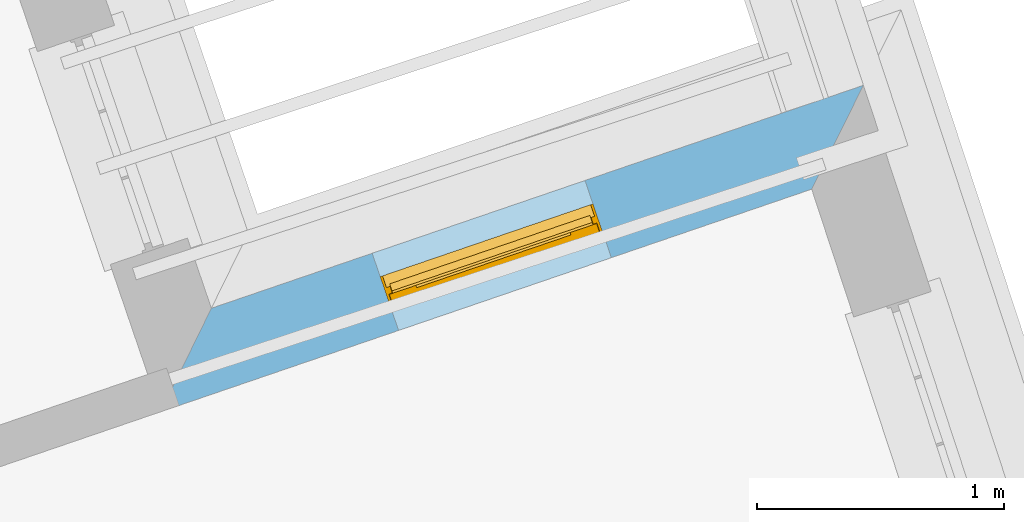
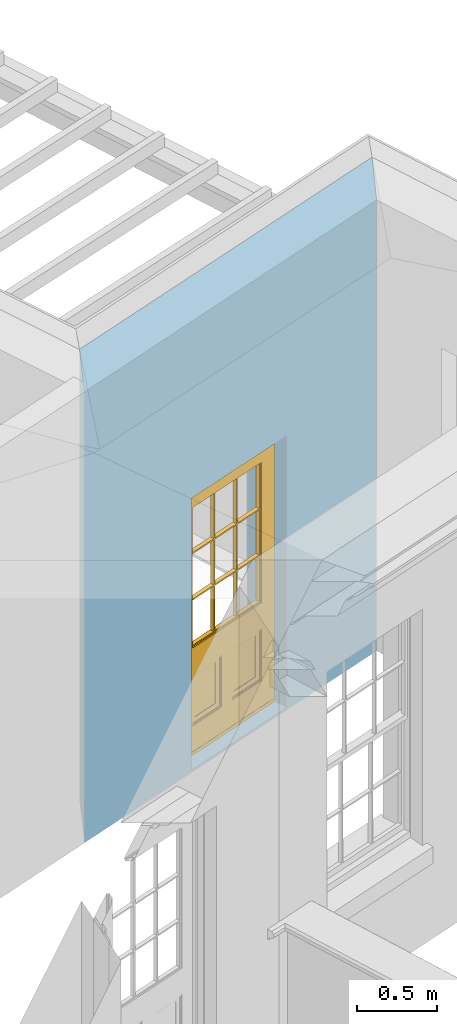
# One storey, part 6 of 10: 1 door, 1 opening, plus 1 element that does not belong to this part.
"""IFC2X3 building model written with IfcOpenShell, lengths in metres."""

from ifc_helpers import new_model, si_unit, frame, origin, place, context, subcontext, project, spatial, polyline, outline, extrude, faceted_brep, material, layer, layer_set, layer_usage, element, fill, save


model = new_model("IFC2X3")

# Units and contexts
model_context = context("Model", 3, world=origin())
body_context = subcontext(model_context, "Body", "Model", "MODEL_VIEW")
ifc_project = project(units=[si_unit("PLANEANGLEUNIT", "RADIAN"), si_unit("MASSUNIT", "GRAM", prefix="KILO"), si_unit("FORCEUNIT", "NEWTON", prefix="KILO"), si_unit("LENGTHUNIT", "METRE")], contexts=[model_context])

# Site, building, storey
site_placement = place(None, origin())
site = spatial("IfcSite", under=ifc_project, at=site_placement, CompositionType="ELEMENT")
building_placement = place(None, origin())
building = spatial("IfcBuilding", under=site, at=building_placement, Name="Building plot-2", CompositionType="ELEMENT")
storey_placement = place(None, frame((0.0, 0.0, 8.2)))
storey = spatial("IfcBuildingStorey", under=building, at=storey_placement, Name="Floor 2", CompositionType="ELEMENT", Elevation=8.2)

# Wall, opening, door
ifc_material = material(Name="Masonry")
ifc_layer = layer(ifc_material, 0.33, ventilated=False)
ifc_layer_set = layer_set([ifc_layer], Name="My Wall")
ifc_layer_usage = layer_usage(ifc_layer_set, "AXIS2", "NEGATIVE", 0.08)
wall_placement = place(storey_placement, origin())
wall = element("IfcWallStandardCase", 1, at=wall_placement, inside=storey, material=ifc_layer_usage, Name="exterior", context=body_context, shape_type="SweptSolid", body=[
    extrude(outline(polyline([(36.0640612033558, 35.8130809593384), (36.2732006834394, 36.2333480972997), (33.6348927431004, 35.33124781613), (33.4294074866547, 34.9122301442074), (36.0640612033558, 35.8130809593384)])), origin(), (0.0, 0.0, 1.0), 3.45),
])
opening_placement = place(storey_placement, frame((0.0, 0.0, 0.0199999999999996)))
opening = element("IfcOpeningElement", 2, at=opening_placement, cuts=wall, Name="Opening", ObjectType="Opening", context=body_context, shape_type="SweptSolid", body=[
    extrude(outline(polyline([(35.146636932067, 35.8481491365074), (34.2855798641652, 35.5537332303196), (34.3923460719036, 35.2414817661354), (35.2534031398054, 35.5358976723233), (35.146636932067, 35.8481491365074)])), origin(), (0.0, 0.0, 1.0), 2.08),
])
door_placement = place(storey_placement, frame((35.2275204227779, 35.611594996974, 0.0199999999999996), z_axis=(0.0, 0.0, 1.0), x_axis=(-0.861057067901783, -0.294415906187808, 0.0)))
door = element("IfcDoor", 3, at=door_placement, inside=storey, Name="circulation outside door", OverallHeight=2.08, OverallWidth=0.91, context=body_context, shape_type="Brep", held_by="IfcProductRepresentation", body=[
    faceted_brep([(0.545, -0.055, 0.265), (0.745, -0.055, 0.265), (0.745, -0.05, 0.265), (0.545, -0.05, 0.265), (0.745, -0.05, 0.58), (0.545, -0.05, 0.58), (0.545, -0.055, 0.58), (0.515, -0.06, 0.235), (0.775, -0.06, 0.235), (0.745, -0.055, 0.58), (0.515, -0.06, 0.61), (0.515, -0.065, 0.235), (0.775, -0.065, 0.235), (0.775, -0.06, 0.61), (0.515, -0.065, 0.61), (0.785, -0.065, 0.225), (0.505, -0.065, 0.225), (0.775, -0.065, 0.61), (0.505, -0.065, 0.62), (0.785, -0.065, 0.62), (0.505, -0.07, 0.225), (0.785, -0.07, 0.225), (0.505, -0.07, 0.62), (0.785, -0.07, 0.62), (0.883, -0.07, 0.075), (0.898, -0.07, 0.075), (0.405, -0.07, 0.62), (0.405, -0.07, 0.225), (0.027, -0.07, 0.075), (0.785, -0.07, 0.82), (0.125, -0.07, 0.82), (0.405, -0.065, 0.62), (0.405, -0.065, 0.225), (0.898, -0.07, 2.068), (0.027, -0.08, 0.075), (0.883, -0.08, 0.075), (0.125, -0.07, 0.225), (0.012, -0.07, 0.075), (0.785, -0.06, 0.82), (0.125, -0.06, 0.82), (0.125, -0.07, 0.62), (0.125, -0.065, 0.62), (0.395, -0.065, 0.61), (0.395, -0.065, 0.235), (0.125, -0.065, 0.225), (0.785, -0.07, 1.895), (0.027, -0.11, 0.045), (0.883, -0.11, 0.045), (0.558333, -0.06, 0.83), (0.351667, -0.06, 0.83), (0.125, -0.07, 1.895), (0.125, -0.06, 1.895), (0.785, -0.06, 1.895), (0.012, -0.07, 2.068), (0.135, -0.065, 0.61), (0.395, -0.06, 0.61), (0.395, -0.06, 0.235), (0.135, -0.065, 0.235), (0.027, -0.11, 0.027), (0.883, -0.11, 0.027), (0.568333, -0.06, 0.83), (0.558333, -0.03, 0.83), (0.351667, -0.03, 0.83), (0.341667, -0.06, 0.83), (0.135, -0.06, 1.185), (0.135, -0.06, 1.53), (0.775, -0.06, 1.53), (0.775, -0.06, 1.185), (0.135, -0.06, 0.61), (0.365, -0.055, 0.58), (0.365, -0.055, 0.265), (0.135, -0.06, 0.235), (0.568333, -0.06, 1.175), (0.558333, -0.06, 1.175), (0.775, -0.06, 0.83), (0.558333, -0.03, 1.175), (0.785, -0.03, 0.82), (0.125, -0.03, 0.82), (0.351667, -0.03, 1.175), (0.351667, -0.06, 1.175), (0.341667, -0.06, 1.175), (0.135, -0.06, 0.83), (0.135, -0.06, 1.175), (0.135, -0.03, 1.185), (0.135, -0.03, 1.53), (0.135, -0.06, 1.54), (0.351667, -0.06, 1.885), (0.558333, -0.06, 1.885), (0.775, -0.03, 1.53), (0.775, -0.03, 1.185), (0.775, -0.06, 1.175), (0.775, -0.06, 1.54), (0.165, -0.055, 0.58), (0.365, -0.05, 0.58), (0.365, -0.05, 0.265), (0.165, -0.055, 0.265), (0.568333, -0.03, 0.83), (0.568333, -0.03, 1.175), (0.568333, -0.06, 1.185), (0.558333, -0.06, 1.185), (0.775, -0.03, 0.83), (0.785, -0.02, 0.82), (0.125, -0.02, 0.82), (0.341667, -0.03, 0.83), (0.341667, -0.03, 1.175), (0.351667, -0.06, 1.185), (0.341667, -0.06, 1.185), (0.135, -0.03, 0.83), (0.341667, -0.03, 1.185), (0.125, -0.03, 1.895), (0.341667, -0.03, 1.53), (0.341667, -0.06, 1.53), (0.135, -0.06, 1.885), (0.341667, -0.06, 1.54), (0.341667, -0.06, 1.885), (0.558333, -0.03, 1.885), (0.351667, -0.03, 1.885), (0.568333, -0.06, 1.885), (0.785, -0.03, 1.895), (0.568333, -0.03, 1.185), (0.568333, -0.06, 1.53), (0.568333, -0.03, 1.53), (0.568333, -0.06, 1.54), (0.775, -0.06, 1.885), (0.165, -0.05, 0.58), (0.165, -0.05, 0.265), (0.775, -0.03, 1.175), (0.558333, -0.06, 1.53), (0.351667, -0.03, 1.185), (0.558333, -0.03, 1.185), (0.505, -0.02, 0.62), (0.405, -0.02, 0.62), (0.125, -0.02, 1.895), (0.785, -0.02, 1.895), (0.351667, -0.06, 1.53), (0.135, -0.03, 1.175), (0.135, -0.03, 1.54), (0.341667, -0.03, 1.54), (0.135, -0.03, 1.885), (0.351667, -0.06, 1.54), (0.558333, -0.03, 1.54), (0.558333, -0.06, 1.54), (0.351667, -0.03, 1.54), (0.775, -0.03, 1.54), (0.568333, -0.03, 1.54), (0.775, -0.03, 1.885), (0.558333, -0.03, 1.53), (0.405, -0.02, 0.225), (0.505, -0.02, 0.225), (0.125, -0.02, 0.62), (0.785, -0.02, 0.62), (0.012, -0.02, 2.068), (0.898, -0.02, 2.068), (0.351667, -0.03, 1.53), (0.341667, -0.03, 1.885), (0.568333, -0.03, 1.885), (0.405, -0.025, 0.225), (0.405, -0.025, 0.62), (0.505, -0.025, 0.62), (0.505, -0.025, 0.225), (0.898, -0.02, 0.027), (0.012, -0.02, 0.027), (0.125, -0.025, 0.62), (0.785, -0.025, 0.62), (0.395, -0.025, 0.235), (0.395, -0.025, 0.61), (0.125, -0.02, 0.225), (0.125, -0.025, 0.225), (0.515, -0.025, 0.61), (0.515, -0.025, 0.235), (0.785, -0.02, 0.225), (0.785, -0.025, 0.225), (0.135, -0.025, 0.61), (0.775, -0.025, 0.61), (0.135, -0.025, 0.235), (0.395, -0.03, 0.235), (0.395, -0.03, 0.61), (0.515, -0.03, 0.61), (0.515, -0.03, 0.235), (0.775, -0.025, 0.235), (0.135, -0.03, 0.61), (0.775, -0.03, 0.61), (0.135, -0.03, 0.235), (0.365, -0.035, 0.265), (0.365, -0.035, 0.58), (0.545, -0.035, 0.58), (0.545, -0.035, 0.265), (0.775, -0.03, 0.235), (0.165, -0.035, 0.58), (0.745, -0.035, 0.58), (0.165, -0.035, 0.265), (0.365, -0.04, 0.58), (0.365, -0.04, 0.265), (0.545, -0.04, 0.58), (0.545, -0.04, 0.265), (0.745, -0.035, 0.265), (0.165, -0.04, 0.58), (0.745, -0.04, 0.58), (0.165, -0.04, 0.265), (0.745, -0.04, 0.265), (0.885, -0.072, 0.025), (0.025, -0.072, 0.025), (0.025, -0.1, 0.025), (0.885, -0.1, 0.025), (0.9, -0.02, 0.025), (0.01, -0.02, 0.025), (0.9, -0.072, 0.025), (0.91, -0.02, 0.0), (0.0, -0.02, 0.0), (0.01, -0.072, 0.025), (0.9, -0.072, 2.07), (0.9, -0.02, 2.07), (0.885, -0.072, 2.055), (0.91, -0.02, 2.08), (0.01, -0.02, 2.07), (0.0, -0.02, 2.08), (0.01, -0.072, 2.07), (0.025, -0.072, 2.055), (0.0, -0.15, 2.08), (0.91, -0.15, 2.08), (0.01, -0.15, 2.07), (0.9, -0.15, 2.07), (0.01, -0.1, 2.07), (0.9, -0.1, 2.07), (0.0, -0.15, 0.0), (0.91, -0.15, 0.0), (0.01, -0.15, 0.025), (0.9, -0.15, 0.025), (0.01, -0.1, 0.025), (0.025, -0.1, 2.055), (0.9, -0.1, 0.025), (0.885, -0.1, 2.055), (0.898, -0.07, 0.027), (0.012, -0.07, 0.027), (0.883, -0.07, 0.027), (0.027, -0.07, 0.027)], [[[0, 1, 2, 3]], [[2, 4, 5, 3]], [[0, 3, 5, 6]], [[1, 0, 7, 8]], [[9, 4, 2, 1]], [[9, 6, 5, 4]], [[0, 6, 10, 7]], [[8, 7, 11, 12]], [[8, 13, 9, 1]], [[13, 10, 6, 9]], [[7, 10, 14, 11]], [[15, 12, 11, 16]], [[12, 17, 13, 8]], [[17, 14, 10, 13]], [[18, 16, 11, 14]], [[15, 19, 17, 12]], [[15, 16, 20, 21]], [[14, 17, 19, 18]], [[16, 18, 22, 20]], [[21, 23, 19, 15]], [[24, 25, 21, 20]], [[23, 22, 18, 19]], [[20, 22, 26, 27]], [[23, 21, 25]], [[28, 24, 20, 27]], [[22, 23, 29]], [[29, 30, 26, 22]], [[27, 26, 31, 32]], [[23, 25, 33, 29]], [[34, 35, 24, 28]], [[28, 27, 36, 37]], [[38, 39, 30, 29]], [[26, 30, 40]], [[26, 40, 41, 31]], [[42, 43, 32, 31]], [[32, 44, 36, 27]], [[33, 45, 29]], [[46, 47, 35, 34]], [[36, 40, 37]], [[39, 38, 48, 49]], [[50, 30, 39, 51]], [[29, 45, 52, 38]], [[53, 37, 40, 30]], [[44, 41, 40, 36]], [[31, 41, 54, 42]], [[43, 42, 55, 56]], [[57, 44, 32, 43]], [[50, 45, 33, 53]], [[47, 46, 58, 59]], [[60, 48, 38]], [[49, 48, 61, 62]], [[49, 63, 39]], [[50, 53, 30]], [[51, 39, 64, 65]], [[45, 50, 51, 52]], [[66, 67, 38, 52]], [[57, 54, 41, 44]], [[42, 54, 68, 55]], [[56, 55, 69, 70]], [[56, 71, 57, 43]], [[60, 72, 73, 48]], [[60, 38, 74]], [[48, 73, 75, 61]], [[76, 77, 62, 61]], [[62, 78, 79, 49]], [[49, 79, 80, 63]], [[63, 81, 39]], [[82, 64, 39]], [[65, 64, 83, 84]], [[85, 51, 65]], [[52, 51, 86, 87]], [[88, 89, 67, 66]], [[90, 38, 67]], [[91, 66, 52]], [[71, 68, 54, 57]], [[55, 68, 92, 69]], [[69, 93, 94, 70]], [[70, 95, 71, 56]], [[96, 97, 72, 60]], [[73, 72, 98, 99]], [[74, 38, 90]], [[100, 96, 60, 74]], [[75, 73, 79, 78]], [[61, 75, 97, 96]], [[101, 102, 77, 76]], [[77, 103, 62]], [[96, 76, 61]], [[103, 104, 78, 62]], [[80, 79, 105, 106]], [[63, 80, 104, 103]], [[81, 63, 103, 107]], [[81, 82, 39]], [[106, 64, 82, 80]], [[106, 108, 83, 64]], [[84, 83, 77, 109]], [[110, 111, 65, 84]], [[112, 51, 85]], [[113, 85, 65, 111]], [[114, 86, 51]], [[115, 87, 86, 116]], [[117, 52, 87]], [[118, 76, 89, 88]], [[119, 98, 67, 89]], [[120, 121, 88, 66]], [[67, 98, 72, 90]], [[91, 122, 120, 66]], [[91, 52, 123]], [[95, 92, 68, 71]], [[69, 92, 124, 93]], [[94, 93, 124, 125]], [[94, 125, 95, 70]], [[72, 97, 126, 90]], [[127, 99, 98, 120]], [[99, 105, 79, 73]], [[74, 90, 126, 100]], [[96, 100, 76]], [[128, 129, 75, 78]], [[97, 75, 129, 119]], [[130, 131, 102, 101]], [[109, 77, 102, 132]], [[133, 101, 76, 118]], [[77, 107, 103]], [[78, 104, 108, 128]], [[111, 106, 105, 134]], [[104, 80, 82, 135]], [[107, 135, 82, 81]], [[110, 108, 106, 111]], [[104, 135, 83, 108]], [[83, 135, 77]], [[136, 84, 109]], [[110, 84, 136, 137]], [[114, 51, 112]], [[85, 136, 138, 112]], [[113, 137, 136, 85]], [[111, 134, 139, 113]], [[86, 114, 113, 139]], [[140, 141, 87, 115]], [[139, 142, 116, 86]], [[109, 118, 115, 116]], [[117, 123, 52]], [[117, 87, 141, 122]], [[126, 89, 76]], [[143, 118, 88]], [[120, 98, 119, 121]], [[119, 89, 126, 97]], [[144, 143, 88, 121]], [[144, 122, 91, 143]], [[127, 120, 122, 141]], [[143, 91, 123, 145]], [[124, 92, 95, 125]], [[146, 129, 99, 127]], [[99, 129, 128, 105]], [[100, 126, 76]], [[121, 119, 129, 146]], [[147, 131, 130, 148]], [[131, 149, 102]], [[130, 101, 150]], [[102, 151, 132]], [[118, 109, 132, 133]], [[101, 133, 152]], [[107, 77, 135]], [[153, 128, 108, 110]], [[134, 105, 128, 153]], [[109, 138, 136]], [[153, 110, 137, 142]], [[154, 114, 112, 138]], [[137, 113, 114, 154]], [[141, 139, 134, 127]], [[141, 140, 142, 139]], [[144, 140, 115, 155]], [[142, 137, 154, 116]], [[155, 115, 118]], [[116, 154, 109]], [[117, 155, 145, 123]], [[122, 144, 155, 117]], [[143, 145, 118]], [[121, 146, 140, 144]], [[146, 127, 134, 153]], [[156, 157, 131, 147]], [[148, 130, 158, 159]], [[148, 160, 161, 147]], [[157, 162, 149, 131]], [[161, 151, 102, 149]], [[101, 152, 160, 150]], [[163, 158, 130, 150]], [[151, 152, 133, 132]], [[154, 138, 109]], [[142, 140, 146, 153]], [[145, 155, 118]], [[157, 156, 164, 165]], [[147, 166, 167, 156]], [[168, 169, 159, 158]], [[170, 148, 159, 171]], [[148, 170, 160]], [[166, 147, 161]], [[172, 162, 157, 165]], [[166, 149, 162, 167]], [[166, 161, 149]], [[150, 160, 170]], [[163, 173, 168, 158]], [[171, 163, 150, 170]], [[174, 164, 156, 167]], [[175, 176, 165, 164]], [[169, 168, 177, 178]], [[171, 159, 169, 179]], [[167, 162, 172, 174]], [[176, 180, 172, 165]], [[179, 173, 163, 171]], [[181, 177, 168, 173]], [[164, 174, 182, 175]], [[183, 184, 176, 175]], [[178, 177, 185, 186]], [[179, 169, 178, 187]], [[174, 172, 180, 182]], [[184, 188, 180, 176]], [[187, 181, 173, 179]], [[189, 185, 177, 181]], [[175, 182, 190, 183]], [[191, 184, 183, 192]], [[185, 193, 194, 186]], [[187, 178, 186, 195]], [[182, 180, 188, 190]], [[191, 196, 188, 184]], [[195, 189, 181, 187]], [[197, 193, 185, 189]], [[183, 190, 198, 192]], [[198, 196, 191, 192]], [[194, 193, 197, 199]], [[195, 186, 194, 199]], [[188, 196, 198, 190]], [[197, 189, 195, 199]], [[200, 201, 202, 203]], [[201, 200, 204, 205]], [[206, 204, 200]], [[204, 207, 208, 205]], [[209, 201, 205]], [[210, 211, 204, 206]], [[206, 200, 212, 210]], [[211, 213, 207, 204]], [[214, 205, 208, 215]], [[216, 217, 201, 209]], [[205, 214, 216, 209]], [[216, 214, 211, 210]], [[210, 212, 217, 216]], [[214, 215, 213, 211]], [[218, 219, 213, 215]], [[219, 218, 220, 221]], [[221, 220, 222, 223]], [[215, 208, 224, 218]], [[225, 224, 208, 207]], [[224, 226, 220, 218]], [[224, 225, 227, 226]], [[219, 225, 207, 213]], [[228, 222, 220, 226]], [[219, 221, 227, 225]], [[226, 227, 203, 202]], [[202, 229, 222, 228]], [[228, 226, 202]], [[227, 221, 223, 230]], [[230, 203, 227]], [[217, 229, 202, 201]], [[231, 223, 222, 229]], [[230, 223, 231, 203]], [[231, 229, 217, 212]], [[212, 200, 203, 231]], [[33, 152, 151, 53]], [[25, 160, 152, 33]], [[161, 37, 53, 151]], [[232, 160, 25]], [[161, 233, 37]], [[160, 232, 234]], [[24, 234, 232, 25]], [[233, 161, 235]], [[37, 233, 235, 28]], [[161, 160, 234, 235]], [[35, 47, 234, 24]], [[28, 235, 46, 34]], [[58, 235, 234, 59]], [[59, 234, 47]], [[58, 46, 235]]]),
])
fill(opening, door)

save(model, "model.ifc")
